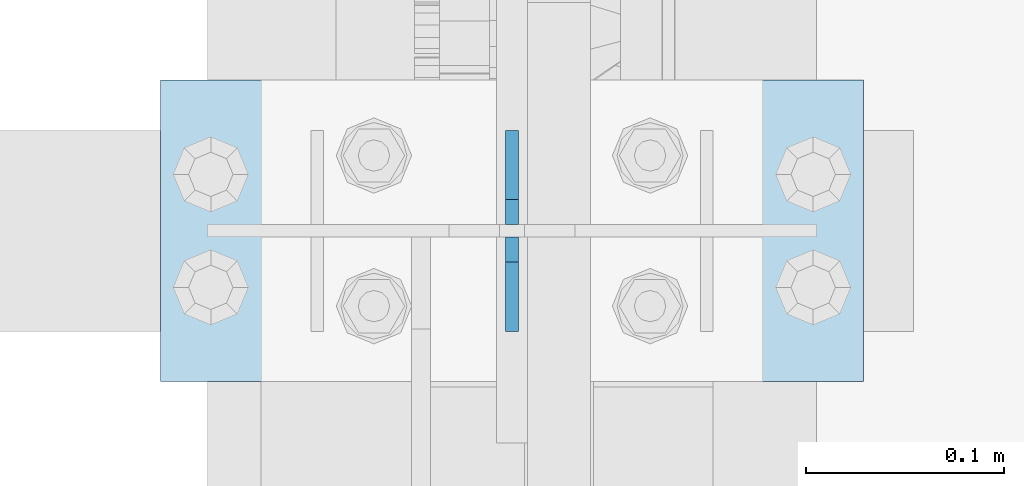
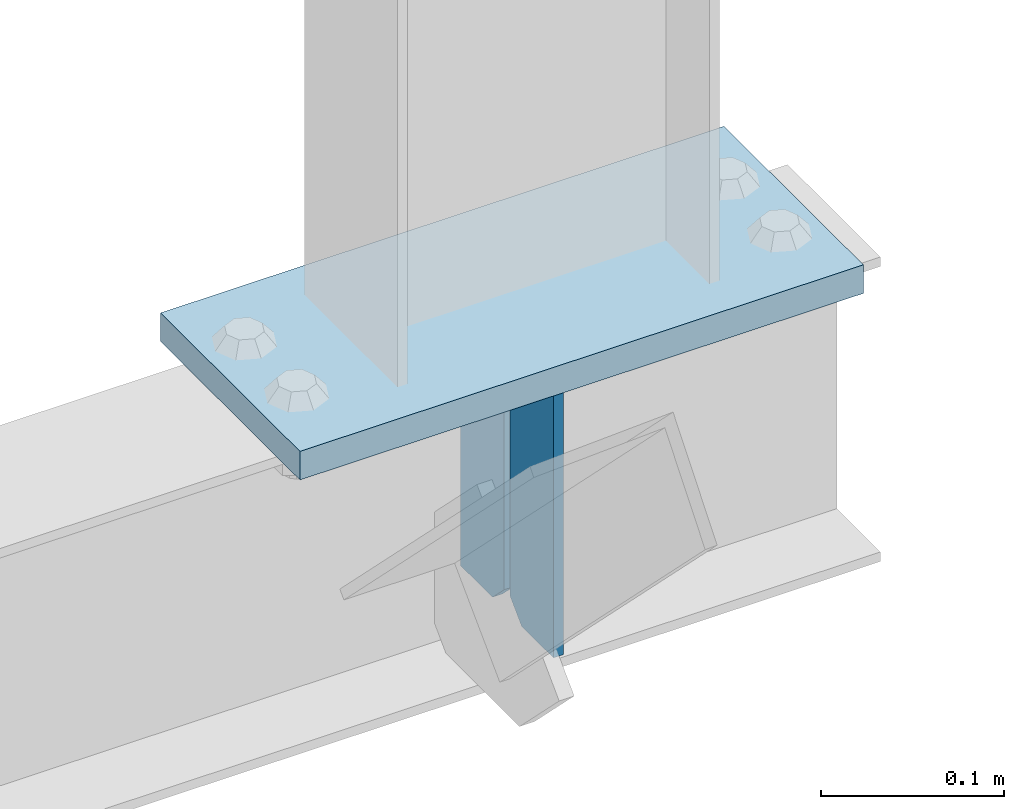
# One storey, part 3420 of 3843: 3 plates, 2 elements without a shape of their own.
"""IFC2X3 building model written with IfcOpenShell, lengths in millimetres."""

from ifc_helpers import new_model, si_unit, frame, origin_with_axes, place, context, subcontext, project, spatial, faceted_brep, material, type_object, element, aggregate, save


model = new_model("IFC2X3")

# Units and contexts
model_context = context("Model", 3, precision=1e-05, world=origin_with_axes())
body_context = subcontext(model_context, "Body", "Model", "MODEL_VIEW")
ifc_project = project(units=[si_unit("LENGTHUNIT", "METRE", prefix="MILLI"), si_unit("AREAUNIT", "SQUARE_METRE"), si_unit("VOLUMEUNIT", "CUBIC_METRE"), si_unit("MASSUNIT", "GRAM", prefix="KILO"), si_unit("TIMEUNIT", "SECOND"), si_unit("PLANEANGLEUNIT", "RADIAN"), si_unit("SOLIDANGLEUNIT", "STERADIAN"), si_unit("THERMODYNAMICTEMPERATUREUNIT", "DEGREE_CELSIUS"), si_unit("LUMINOUSINTENSITYUNIT", "LUMEN")], contexts=[model_context])

# Site, building, storey
site_placement = place(None, origin_with_axes())
site = spatial("IfcSite", under=ifc_project, at=site_placement, CompositionType="ELEMENT")
building_placement = place(site_placement, origin_with_axes())
building = spatial("IfcBuilding", under=site, at=building_placement, Name="Undefined", CompositionType="ELEMENT")
storey_placement = place(building_placement, origin_with_axes())
storey = spatial("IfcBuildingStorey", under=building, at=storey_placement, Name="Undefined", CompositionType="ELEMENT", Elevation=0.0)

# Assembly, plates
assembly_1_placement = place(storey_placement, origin_with_axes())
assembly_1 = element("IfcElementAssembly", 1, at=assembly_1_placement, inside=storey, Name="BEAM", AssemblyPlace="NOTDEFINED", PredefinedType="RIGID_FRAME")
ifc_material = material(Name="STEEL/A572-50")
plate_type_1 = type_object("IfcPlateType", PredefinedType="NOTDEFINED")
plate_1_placement = place(assembly_1_placement, frame((42062.4, 90792.3, 41495.6625), z_axis=(0.0, 0.0, -1.0), x_axis=(0.0, 1.0, 0.0)))
plate_1 = element("IfcPlate", 2, at=plate_1_placement, type_object=plate_type_1, material=ifc_material, Name="PLATE", context=body_context, shape_type="Brep", body=[
    faceted_brep([(0.0, -3.17499999999927, 0.0), (0.0, -3.17500000000291, 187.324999999997), (0.0, 3.17500000000291, 187.324999999997), (0.0, 3.17499999999927, 0.0), (34.9250001907349, -3.17500000000291, 187.324999999997), (34.9250001907349, 3.17500000000291, 187.324999999997), (47.625, -3.17500000000291, 174.625000190732), (47.625, 3.17500000000291, 174.625000190732), (47.625, -3.17499999999927, 12.6999998092651), (47.625, 3.17499999999927, 12.6999998092651), (34.9250001907349, -3.17499999999927, 0.0), (34.9250001907349, 3.17499999999927, 0.0)], [[[0, 1, 2, 3]], [[1, 4, 5, 2]], [[4, 6, 7, 5]], [[6, 8, 9, 7]], [[8, 10, 11, 9]], [[10, 0, 3, 11]], [[5, 7, 9, 11, 3, 2]], [[10, 8, 6, 4, 1, 0]]]),
])
plate_2_placement = place(assembly_1_placement, frame((42062.4, 90893.9, 41495.6625), z_axis=(0.0, 0.0, -1.0), x_axis=(0.0, -1.0, 0.0)))
plate_2 = element("IfcPlate", 3, at=plate_2_placement, type_object=plate_type_1, material=ifc_material, Name="PLATE", context=body_context, shape_type="Brep", body=[
    faceted_brep([(0.0, -3.17499999999927, 0.0), (0.0, -3.17500000000291, 187.324999999997), (0.0, 3.17500000000291, 187.324999999997), (0.0, 3.17499999999927, 0.0), (34.9250001907349, -3.17500000000291, 187.324999999997), (34.9250001907349, 3.17500000000291, 187.324999999997), (47.625, -3.17500000000291, 174.625000190732), (47.625, 3.17500000000291, 174.625000190732), (47.625, -3.17499999999927, 12.6999998092651), (47.625, 3.17499999999927, 12.6999998092651), (34.9250001907349, -3.17499999999927, 0.0), (34.9250001907349, 3.17499999999927, 0.0)], [[[0, 1, 2, 3]], [[1, 4, 5, 2]], [[4, 6, 7, 5]], [[6, 8, 9, 7]], [[8, 10, 11, 9]], [[10, 0, 3, 11]], [[5, 7, 9, 11, 3, 2]], [[10, 8, 6, 4, 1, 0]]]),
])
aggregate(assembly_1, [plate_1, plate_2])

# Assembly, plate
assembly_2_placement = place(storey_placement, origin_with_axes())
assembly_2 = element("IfcElementAssembly", 4, at=assembly_2_placement, inside=storey, Name="POST", AssemblyPlace="NOTDEFINED", PredefinedType="RIGID_FRAME")
plate_type_2 = type_object("IfcPlateType", PredefinedType="NOTDEFINED")
plate_3_placement = place(assembly_2_placement, frame((42240.2, 90766.9, 41513.125), z_axis=(-1.0, 0.0, 0.0), x_axis=(0.0, 1.0, 0.0)))
plate_3 = element("IfcPlate", 5, at=plate_3_placement, type_object=plate_type_2, material=ifc_material, Name="PLATE", context=body_context, shape_type="Brep", body=[
    faceted_brep([(0.0, -9.52500000000146, 0.0), (0.0, -9.52500000000146, 355.599999999999), (0.0, 9.52500000000146, 355.599999999999), (0.0, 9.52500000000146, 0.0), (152.399999999994, -9.52500000000146, 355.599999999999), (152.399999999994, 9.52500000000146, 355.599999999999), (152.400000000001, -9.52500000000146, 0.0), (152.400000000001, 9.52500000000146, 0.0)], [[[0, 1, 2, 3]], [[1, 4, 5, 2]], [[4, 6, 7, 5]], [[6, 0, 3, 7]], [[5, 7, 3, 2]], [[6, 4, 1, 0]]]),
])
aggregate(assembly_2, [plate_3])

save(model, "model.ifc")
